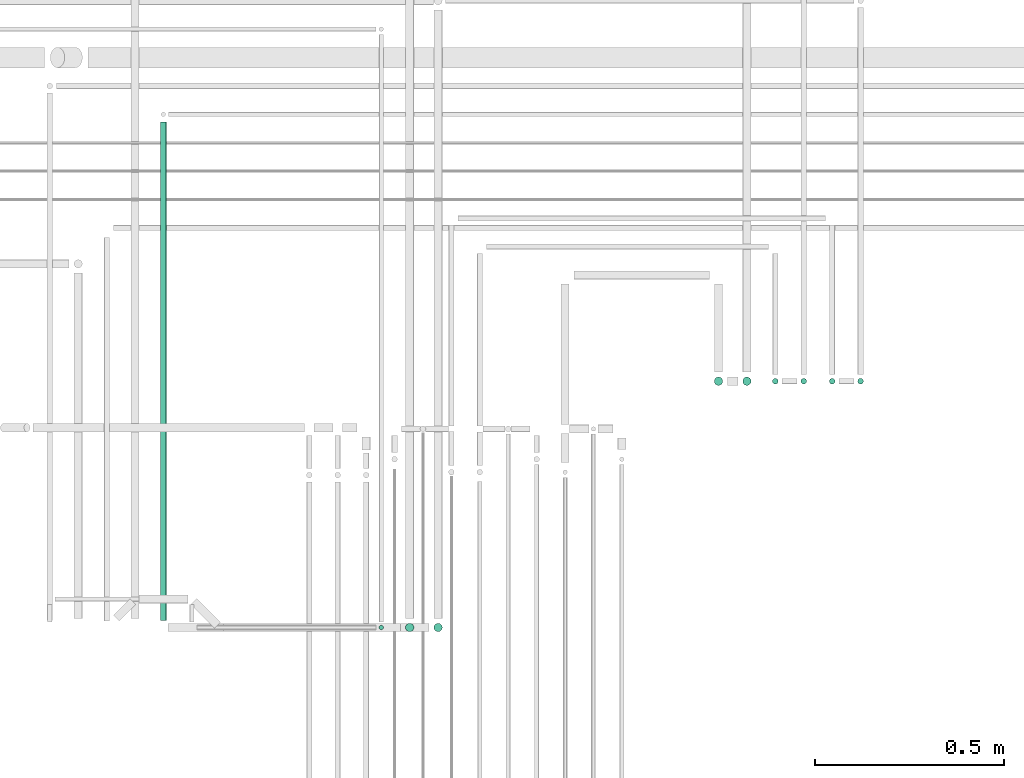
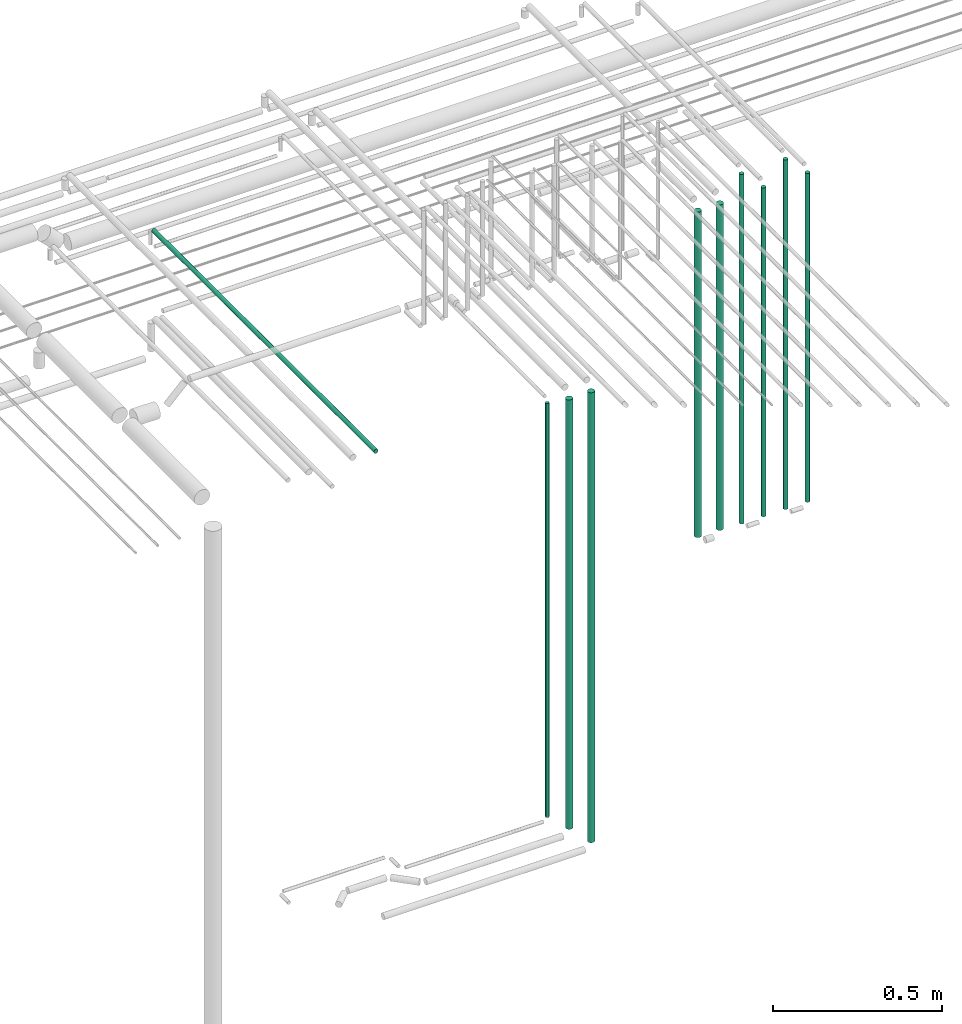
# One storey, part 25 of 65: 10 flow segments.
"""IFC2X3 building model written with IfcOpenShell, lengths in millimetres."""

from ifc_helpers import new_model, entity, si_unit, converted_unit, derived_unit, direction, frame, origin, origin_2d_with_axis, place, context, subcontext, project, spatial, circle, extrude, type_object, element, save


model = new_model("IFC2X3")

# Units and contexts
model_context = context("Model", 3, precision=0.01, world=origin(), true_north=direction((6.12303176911189e-17, 1.0)))
body_context = subcontext(model_context, "Body", "Model", "MODEL_VIEW")
ifc_project = project(units=[si_unit("LENGTHUNIT", "METRE", prefix="MILLI"), si_unit("AREAUNIT", "SQUARE_METRE"), si_unit("VOLUMEUNIT", "CUBIC_METRE"), converted_unit("PLANEANGLEUNIT", "DEGREE", entity("IfcRatioMeasure", 0.0174532925199433), si_unit("PLANEANGLEUNIT", "RADIAN"), dimensions=[0, 0, 0, 0, 0, 0, 0]), si_unit("MASSUNIT", "GRAM", prefix="KILO"), derived_unit("MASSDENSITYUNIT", [(si_unit("MASSUNIT", "GRAM", prefix="KILO"), 1), (si_unit("LENGTHUNIT", "METRE"), -3)]), derived_unit("MOMENTOFINERTIAUNIT", [(si_unit("LENGTHUNIT", "METRE"), 4)]), si_unit("TIMEUNIT", "SECOND"), si_unit("FREQUENCYUNIT", "HERTZ"), si_unit("THERMODYNAMICTEMPERATUREUNIT", "DEGREE_CELSIUS"), derived_unit("THERMALTRANSMITTANCEUNIT", [(si_unit("MASSUNIT", "GRAM", prefix="KILO"), 1), (si_unit("THERMODYNAMICTEMPERATUREUNIT", "KELVIN"), -1), (si_unit("TIMEUNIT", "SECOND"), -3)]), derived_unit("VOLUMETRICFLOWRATEUNIT", [(si_unit("LENGTHUNIT", "METRE"), 3), (si_unit("TIMEUNIT", "SECOND"), -1)]), derived_unit("MASSFLOWRATEUNIT", [(si_unit("MASSUNIT", "GRAM", prefix="KILO"), 1), (si_unit("TIMEUNIT", "SECOND"), -1)]), derived_unit("ROTATIONALFREQUENCYUNIT", [(si_unit("TIMEUNIT", "SECOND"), -1)]), si_unit("ELECTRICCURRENTUNIT", "AMPERE"), si_unit("ELECTRICVOLTAGEUNIT", "VOLT"), si_unit("POWERUNIT", "WATT"), si_unit("FORCEUNIT", "NEWTON", prefix="KILO"), si_unit("ILLUMINANCEUNIT", "LUX"), si_unit("LUMINOUSFLUXUNIT", "LUMEN"), si_unit("LUMINOUSINTENSITYUNIT", "CANDELA"), derived_unit("USERDEFINED", [(si_unit("MASSUNIT", "GRAM", prefix="KILO"), -1), (si_unit("LENGTHUNIT", "METRE"), -2), (si_unit("TIMEUNIT", "SECOND"), 3), (si_unit("LUMINOUSFLUXUNIT", "LUMEN"), 1)]), derived_unit("LINEARVELOCITYUNIT", [(si_unit("LENGTHUNIT", "METRE"), 1), (si_unit("TIMEUNIT", "SECOND"), -1)]), si_unit("PRESSUREUNIT", "PASCAL"), derived_unit("USERDEFINED", [(si_unit("LENGTHUNIT", "METRE"), -2), (si_unit("MASSUNIT", "GRAM", prefix="KILO"), 1), (si_unit("TIMEUNIT", "SECOND"), -2)]), derived_unit("LINEARFORCEUNIT", [(si_unit("MASSUNIT", "GRAM", prefix="KILO"), 1), (si_unit("LENGTHUNIT", "METRE"), 1), (si_unit("TIMEUNIT", "SECOND"), -2), (si_unit("LENGTHUNIT", "METRE"), -1)]), derived_unit("PLANARFORCEUNIT", [(si_unit("MASSUNIT", "GRAM", prefix="KILO"), 1), (si_unit("LENGTHUNIT", "METRE"), 1), (si_unit("TIMEUNIT", "SECOND"), -2), (si_unit("LENGTHUNIT", "METRE"), -2)])], contexts=[model_context])

# Site, building, storey
site_placement = place(None, frame((0.0, -0.00077364408347762, 0.0)))
site = spatial("IfcSite", under=ifc_project, at=site_placement, CompositionType="ELEMENT")
building_placement = place(site_placement, origin())
building = spatial("IfcBuilding", under=site, at=building_placement, CompositionType="ELEMENT")
storey_placement = place(building_placement, frame((0.0, 0.0, 19800.0)))
storey = spatial("IfcBuildingStorey", under=building, at=storey_placement, CompositionType="ELEMENT", Elevation=19800.0)

# Flow segments
pipe_segment_type = type_object("IfcPipeSegmentType", PredefinedType="NOTDEFINED")
flow_segment_1_placement = place(storey_placement, frame((66287.5166110418, 7652.55397759734, 1049.0)))
element("IfcFlowSegment", 1, at=flow_segment_1_placement, inside=storey, type_object=pipe_segment_type, context=body_context, shape_type="SweptSolid", body=[
    extrude(circle(Radius=11.0, at=origin_2d_with_axis()), frame((12.5952722359134, 12.5952722359156, 0.0), z_axis=(0.0, 0.0, 1.0), x_axis=(-1.0, 0.0, 0.0)), (0.0, 0.0, 1.0), 1552.00000000003),
])
flow_segment_2_placement = place(storey_placement, frame((67177.5166110417, 8302.55397754014, 1424.0)))
element("IfcFlowSegment", 2, at=flow_segment_2_placement, inside=storey, type_object=pipe_segment_type, context=body_context, shape_type="SweptSolid", body=[
    extrude(circle(Radius=11.0, at=origin_2d_with_axis()), frame((12.5952722359134, 12.5952722359156, 0.0)), (0.0, 0.0, 1.0), 1177.00000000002),
])
flow_segment_3_placement = place(storey_placement, frame((67102.5166110417, 8302.55397754015, 1424.0)))
element("IfcFlowSegment", 3, at=flow_segment_3_placement, inside=storey, type_object=pipe_segment_type, context=body_context, shape_type="SweptSolid", body=[
    extrude(circle(Radius=11.0, at=origin_2d_with_axis()), frame((12.5952722359134, 12.5952722359156, 0.0), z_axis=(0.0, 0.0, 1.0), x_axis=(-1.0, 0.0, 0.0)), (0.0, 0.0, 1.0), 1177.00000000001),
])
flow_segment_4_placement = place(storey_placement, frame((65641.0166110417, 7683.14924983325, 2615.9047277641)))
element("IfcFlowSegment", 4, at=flow_segment_4_placement, inside=storey, type_object=pipe_segment_type, context=body_context, shape_type="SweptSolid", body=[
    extrude(circle(Radius=7.5, at=origin_2d_with_axis()), frame((9.09527223591419, 0.0, 9.09527223591419), z_axis=(0.0, 1.0, 0.0), x_axis=(-1.0, 0.0, 0.0)), (0.0, 0.0, 1.0), 1316.30342164311),
])
flow_segment_5_placement = place(storey_placement, frame((66217.5166110417, 7657.55397759734, 1114.0)))
element("IfcFlowSegment", 5, at=flow_segment_5_placement, inside=storey, type_object=pipe_segment_type, context=body_context, shape_type="SweptSolid", body=[
    extrude(circle(Radius=6.0, at=origin_2d_with_axis()), frame((7.59527223591454, 7.59527223591562, 0.0)), (0.0, 0.0, 1.0), 1497.00000000005),
])
flow_segment_6_placement = place(storey_placement, frame((66362.5166110418, 7652.55397759734, 974.0)))
element("IfcFlowSegment", 6, at=flow_segment_6_placement, inside=storey, type_object=pipe_segment_type, context=body_context, shape_type="SweptSolid", body=[
    extrude(circle(Radius=11.0, at=origin_2d_with_axis()), frame((12.5952722359134, 12.5952722359156, 0.0), z_axis=(0.0, 0.0, 1.0), x_axis=(-1.0, 0.0, 0.0)), (0.0, 0.0, 1.0), 1627.00000000003),
])
flow_segment_7_placement = place(storey_placement, frame((67331.0166110417, 8306.05397754014, 1418.0)))
element("IfcFlowSegment", 7, at=flow_segment_7_placement, inside=storey, type_object=pipe_segment_type, context=body_context, shape_type="SweptSolid", body=[
    extrude(circle(Radius=7.5, at=origin_2d_with_axis()), frame((9.09527223591419, 9.09527223591636, 0.0)), (0.0, 0.0, 1.0), 1189.00000000002),
])
flow_segment_8_placement = place(storey_placement, frame((67256.0166110417, 8306.05397754015, 1418.0)))
element("IfcFlowSegment", 8, at=flow_segment_8_placement, inside=storey, type_object=pipe_segment_type, context=body_context, shape_type="SweptSolid", body=[
    extrude(circle(Radius=7.5, at=origin_2d_with_axis()), frame((9.09527223591419, 9.09527223591636, 0.0), z_axis=(0.0, 0.0, 1.0), x_axis=(-1.0, 0.0, 0.0)), (0.0, 0.0, 1.0), 1264.0),
])
flow_segment_9_placement = place(storey_placement, frame((67481.0166110417, 8306.05397754014, 1418.0)))
element("IfcFlowSegment", 9, at=flow_segment_9_placement, inside=storey, type_object=pipe_segment_type, context=body_context, shape_type="SweptSolid", body=[
    extrude(circle(Radius=7.5, at=origin_2d_with_axis()), frame((9.09527223591419, 9.09527223591636, 0.0)), (0.0, 0.0, 1.0), 1189.00000000002),
])
flow_segment_10_placement = place(storey_placement, frame((67406.0166110417, 8306.05397754015, 1418.0)))
element("IfcFlowSegment", 10, at=flow_segment_10_placement, inside=storey, type_object=pipe_segment_type, context=body_context, shape_type="SweptSolid", body=[
    extrude(circle(Radius=7.5, at=origin_2d_with_axis()), frame((9.09527223591419, 9.09527223591636, 0.0), z_axis=(0.0, 0.0, 1.0), x_axis=(-1.0, 0.0, 0.0)), (0.0, 0.0, 1.0), 1264.0),
])

save(model, "model.ifc")
